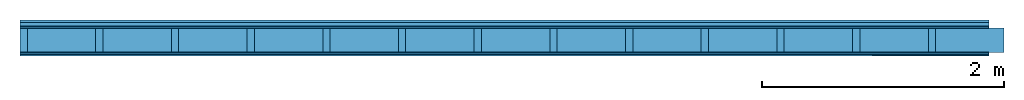
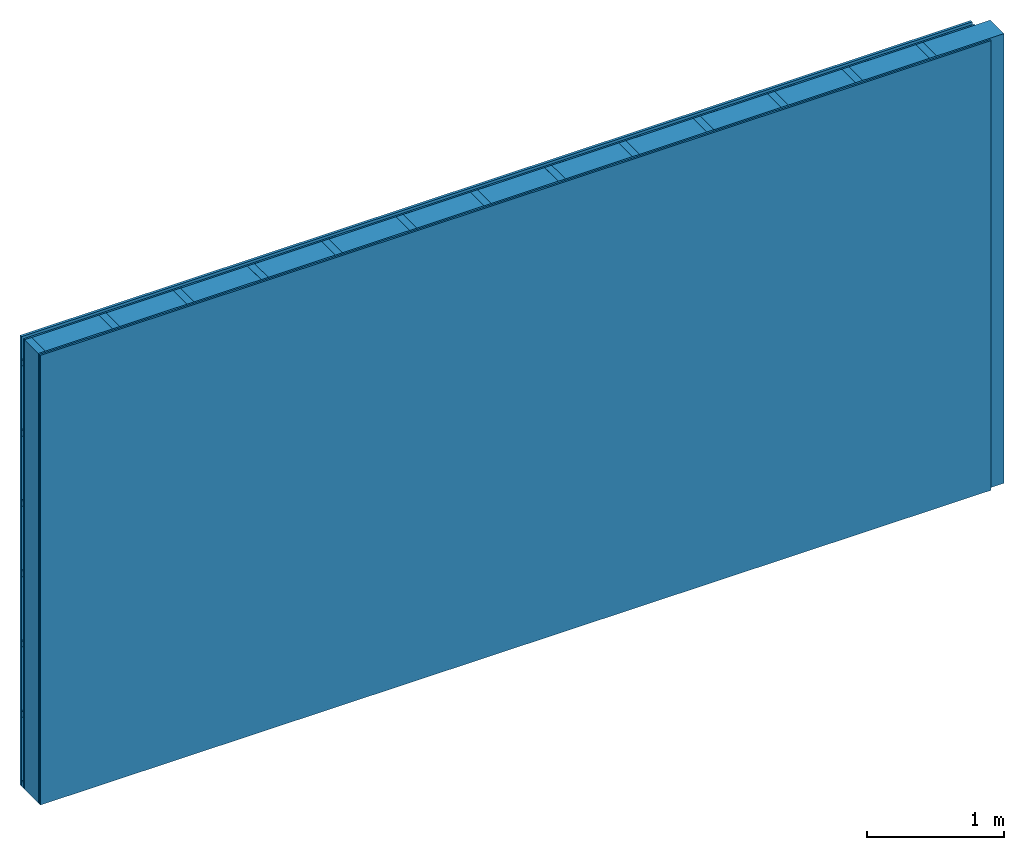
# One storey: 4 plates, 3 members, 1 element without a shape of its own.
"""IFC4 building model written with IfcOpenShell, lengths in metres."""

from ifc_helpers import new_model, si_unit, derived_unit, direction, frame, frame_2d, origin, origin_with_axes, place, context, project, spatial, rectangle, extrude, material, layer, layer_set, type_object, element, aggregate, save


model = new_model("IFC4")

# Units and contexts
plan_context = context("Plan", 3, precision=1e-05, world=origin(), true_north=direction((0.0, 1.0)))
model_context = context("Model", 3, precision=1e-05, world=origin(), true_north=direction((0.0, 1.0)))
ifc_project = project(units=[si_unit("LENGTHUNIT", "METRE"), derived_unit("SOUNDPRESSUREUNIT", [(si_unit("PRESSUREUNIT", "PASCAL", prefix="MICRO"), 0)]), si_unit("ENERGYUNIT", "JOULE", prefix="MEGA"), si_unit("MASSUNIT", "GRAM", prefix="KILO"), derived_unit("THERMALTRANSMITTANCEUNIT", [(si_unit("POWERUNIT", "WATT"), 1), (si_unit("AREAUNIT", "SQUARE_METRE"), -1), (si_unit("THERMODYNAMICTEMPERATUREUNIT", "KELVIN"), -1)]), derived_unit("AREADENSITYUNIT", [(si_unit("MASSUNIT", "GRAM", prefix="KILO"), 1), (si_unit("AREAUNIT", "SQUARE_METRE"), -1)]), derived_unit("USERDEFINED", [(si_unit("ENERGYUNIT", "JOULE", prefix="MEGA"), 1), (si_unit("AREAUNIT", "SQUARE_METRE"), -1)])], contexts=[plan_context, model_context])

# Site, building, storey
site = spatial("IfcSite", under=ifc_project)
building_placement = place(None, origin())
building = spatial("IfcBuilding", under=site, at=building_placement)
storey_placement = place(building_placement, origin())
storey = spatial("IfcBuildingStorey", under=building, at=storey_placement)

# Wall, members, plates
ifc_material_1 = material(Name="Wood cladding horizontal, closed")
ifc_layer_1 = layer(ifc_material_1, 0.022, Name="Cover 1st layer")
ifc_layer_2 = layer(None, 0.03, Name="Battens / profiles (ventilation)")
ifc_material_2 = material(Category="03.007")
ifc_layer_3 = layer(ifc_material_2, 0.015, Name="outside 1st layer")
ifc_material_3 = material(Name="of the art")
ifc_layer_4 = layer(ifc_material_3, 0.0, Name="Bond")
ifc_layer_5 = layer(None, 0.2, Name="Support")
ifc_layer_6 = layer(ifc_material_3, 0.0, Name="Bond")
ifc_material_4 = material(Category="07.013")
ifc_layer_7 = layer(ifc_material_4, 0.015, Name="1st layer")
ifc_material_5 = material(Name="Plasterboard type A", Category="03.008")
ifc_layer_8 = layer(ifc_material_5, 0.015, Name="2nd layer")
ifc_material_6 = material(Name="joints", Category="04.017")
ifc_layer_9 = layer(ifc_material_6, 0.0, Name="Surface")
ifc_layer_set = layer_set([ifc_layer_1, ifc_layer_2, ifc_layer_3, ifc_layer_4, ifc_layer_5, ifc_layer_6, ifc_layer_7, ifc_layer_8, ifc_layer_9])
wall_type = type_object("IfcWallType", Name="D0128", PredefinedType="NOTDEFINED", material=ifc_layer_set)
wall_placement = place(None, frame((0.0, 0.0, 0.0), z_axis=(0.0, -1.0, 0.0), x_axis=(1.0, 0.0, 0.0)))
wall = element("IfcWall", 1, at=wall_placement, inside=storey, type_object=wall_type, material=ifc_layer_set, Name="Wall #1")
ifc_material_7 = material()
member_1_placement = place(wall_placement, origin())
member_1 = element("IfcMember", 2, at=member_1_placement, material=ifc_material_7, Name="Battens / profiles (ventilation)", context=plan_context, shape_type="SweptSolid", body=[
    extrude(rectangle(XDim=0.05, YDim=0.03, at=frame_2d((0.025, 0.015), x_axis=(1.0, 0.0))), frame((0.0, 0.0, 0.022), z_axis=(1.0, 0.0, 0.0), x_axis=(0.0, 1.0, 0.0)), (0.0, 0.0, 1.0), 8.0),
    extrude(rectangle(XDim=0.05, YDim=0.03, at=frame_2d((0.025, 0.015), x_axis=(1.0, 0.0))), frame((0.0, 0.625, 0.022), z_axis=(1.0, 0.0, 0.0), x_axis=(0.0, 1.0, 0.0)), (0.0, 0.0, 1.0), 8.0),
    extrude(rectangle(XDim=0.05, YDim=0.03, at=frame_2d((0.025, 0.015), x_axis=(1.0, 0.0))), frame((0.0, 1.25, 0.022), z_axis=(1.0, 0.0, 0.0), x_axis=(0.0, 1.0, 0.0)), (0.0, 0.0, 1.0), 8.0),
    extrude(rectangle(XDim=0.05, YDim=0.03, at=frame_2d((0.025, 0.015), x_axis=(1.0, 0.0))), frame((0.0, 1.875, 0.022), z_axis=(1.0, 0.0, 0.0), x_axis=(0.0, 1.0, 0.0)), (0.0, 0.0, 1.0), 8.0),
    extrude(rectangle(XDim=0.05, YDim=0.03, at=frame_2d((0.025, 0.015), x_axis=(1.0, 0.0))), frame((0.0, 2.5, 0.022), z_axis=(1.0, 0.0, 0.0), x_axis=(0.0, 1.0, 0.0)), (0.0, 0.0, 1.0), 8.0),
    extrude(rectangle(XDim=0.05, YDim=0.03, at=frame_2d((0.025, 0.015), x_axis=(1.0, 0.0))), frame((0.0, 3.125, 0.022), z_axis=(1.0, 0.0, 0.0), x_axis=(0.0, 1.0, 0.0)), (0.0, 0.0, 1.0), 8.0),
    extrude(rectangle(XDim=0.05, YDim=0.03, at=frame_2d((0.025, 0.015), x_axis=(1.0, 0.0))), frame((0.0, 3.75, 0.022), z_axis=(1.0, 0.0, 0.0), x_axis=(0.0, 1.0, 0.0)), (0.0, 0.0, 1.0), 8.0),
])
ifc_material_8 = material()
member_2_placement = place(wall_placement, origin())
member_2 = element("IfcMember", 3, at=member_2_placement, material=ifc_material_8, Name="Support", context=plan_context, shape_type="SweptSolid", body=[
    extrude(rectangle(XDim=0.06, YDim=0.2, at=frame_2d((0.03, 0.1), x_axis=(1.0, 0.0))), frame((0.0, 4.0, 0.067), z_axis=(0.0, -1.0, 0.0), x_axis=(1.0, 0.0, 0.0)), (0.0, 0.0, 1.0), 4.0),
    extrude(rectangle(XDim=0.06, YDim=0.2, at=frame_2d((0.03, 0.1), x_axis=(1.0, 0.0))), frame((0.625, 4.0, 0.067), z_axis=(0.0, -1.0, 0.0), x_axis=(1.0, 0.0, 0.0)), (0.0, 0.0, 1.0), 4.0),
    extrude(rectangle(XDim=0.06, YDim=0.2, at=frame_2d((0.03, 0.1), x_axis=(1.0, 0.0))), frame((1.25, 4.0, 0.067), z_axis=(0.0, -1.0, 0.0), x_axis=(1.0, 0.0, 0.0)), (0.0, 0.0, 1.0), 4.0),
    extrude(rectangle(XDim=0.06, YDim=0.2, at=frame_2d((0.03, 0.1), x_axis=(1.0, 0.0))), frame((1.875, 4.0, 0.067), z_axis=(0.0, -1.0, 0.0), x_axis=(1.0, 0.0, 0.0)), (0.0, 0.0, 1.0), 4.0),
    extrude(rectangle(XDim=0.06, YDim=0.2, at=frame_2d((0.03, 0.1), x_axis=(1.0, 0.0))), frame((2.5, 4.0, 0.067), z_axis=(0.0, -1.0, 0.0), x_axis=(1.0, 0.0, 0.0)), (0.0, 0.0, 1.0), 4.0),
    extrude(rectangle(XDim=0.06, YDim=0.2, at=frame_2d((0.03, 0.1), x_axis=(1.0, 0.0))), frame((3.125, 4.0, 0.067), z_axis=(0.0, -1.0, 0.0), x_axis=(1.0, 0.0, 0.0)), (0.0, 0.0, 1.0), 4.0),
    extrude(rectangle(XDim=0.06, YDim=0.2, at=frame_2d((0.03, 0.1), x_axis=(1.0, 0.0))), frame((3.75, 4.0, 0.067), z_axis=(0.0, -1.0, 0.0), x_axis=(1.0, 0.0, 0.0)), (0.0, 0.0, 1.0), 4.0),
    extrude(rectangle(XDim=0.06, YDim=0.2, at=frame_2d((0.03, 0.1), x_axis=(1.0, 0.0))), frame((4.375, 4.0, 0.067), z_axis=(0.0, -1.0, 0.0), x_axis=(1.0, 0.0, 0.0)), (0.0, 0.0, 1.0), 4.0),
    extrude(rectangle(XDim=0.06, YDim=0.2, at=frame_2d((0.03, 0.1), x_axis=(1.0, 0.0))), frame((5.0, 4.0, 0.067), z_axis=(0.0, -1.0, 0.0), x_axis=(1.0, 0.0, 0.0)), (0.0, 0.0, 1.0), 4.0),
    extrude(rectangle(XDim=0.06, YDim=0.2, at=frame_2d((0.03, 0.1), x_axis=(1.0, 0.0))), frame((5.625, 4.0, 0.067), z_axis=(0.0, -1.0, 0.0), x_axis=(1.0, 0.0, 0.0)), (0.0, 0.0, 1.0), 4.0),
    extrude(rectangle(XDim=0.06, YDim=0.2, at=frame_2d((0.03, 0.1), x_axis=(1.0, 0.0))), frame((6.25, 4.0, 0.067), z_axis=(0.0, -1.0, 0.0), x_axis=(1.0, 0.0, 0.0)), (0.0, 0.0, 1.0), 4.0),
    extrude(rectangle(XDim=0.06, YDim=0.2, at=frame_2d((0.03, 0.1), x_axis=(1.0, 0.0))), frame((6.875, 4.0, 0.067), z_axis=(0.0, -1.0, 0.0), x_axis=(1.0, 0.0, 0.0)), (0.0, 0.0, 1.0), 4.0),
    extrude(rectangle(XDim=0.06, YDim=0.2, at=frame_2d((0.03, 0.1), x_axis=(1.0, 0.0))), frame((7.5, 4.0, 0.067), z_axis=(0.0, -1.0, 0.0), x_axis=(1.0, 0.0, 0.0)), (0.0, 0.0, 1.0), 4.0),
])
ifc_material_9 = material()
member_3_placement = place(wall_placement, origin())
member_3 = element("IfcMember", 4, at=member_3_placement, material=ifc_material_9, Name="Cavity", context=plan_context, shape_type="SweptSolid", body=[
    extrude(rectangle(XDim=0.565, YDim=0.2, at=frame_2d((0.2825, 0.1), x_axis=(1.0, 0.0))), frame((0.06, 4.0, 0.067), z_axis=(0.0, -1.0, 0.0), x_axis=(1.0, 0.0, 0.0)), (0.0, 0.0, 1.0), 4.0),
    extrude(rectangle(XDim=0.565, YDim=0.2, at=frame_2d((0.2825, 0.1), x_axis=(1.0, 0.0))), frame((0.685, 4.0, 0.067), z_axis=(0.0, -1.0, 0.0), x_axis=(1.0, 0.0, 0.0)), (0.0, 0.0, 1.0), 4.0),
    extrude(rectangle(XDim=0.565, YDim=0.2, at=frame_2d((0.2825, 0.1), x_axis=(1.0, 0.0))), frame((1.31, 4.0, 0.067), z_axis=(0.0, -1.0, 0.0), x_axis=(1.0, 0.0, 0.0)), (0.0, 0.0, 1.0), 4.0),
    extrude(rectangle(XDim=0.565, YDim=0.2, at=frame_2d((0.2825, 0.1), x_axis=(1.0, 0.0))), frame((1.935, 4.0, 0.067), z_axis=(0.0, -1.0, 0.0), x_axis=(1.0, 0.0, 0.0)), (0.0, 0.0, 1.0), 4.0),
    extrude(rectangle(XDim=0.565, YDim=0.2, at=frame_2d((0.2825, 0.1), x_axis=(1.0, 0.0))), frame((2.56, 4.0, 0.067), z_axis=(0.0, -1.0, 0.0), x_axis=(1.0, 0.0, 0.0)), (0.0, 0.0, 1.0), 4.0),
    extrude(rectangle(XDim=0.565, YDim=0.2, at=frame_2d((0.2825, 0.1), x_axis=(1.0, 0.0))), frame((3.185, 4.0, 0.067), z_axis=(0.0, -1.0, 0.0), x_axis=(1.0, 0.0, 0.0)), (0.0, 0.0, 1.0), 4.0),
    extrude(rectangle(XDim=0.565, YDim=0.2, at=frame_2d((0.2825, 0.1), x_axis=(1.0, 0.0))), frame((3.81, 4.0, 0.067), z_axis=(0.0, -1.0, 0.0), x_axis=(1.0, 0.0, 0.0)), (0.0, 0.0, 1.0), 4.0),
    extrude(rectangle(XDim=0.565, YDim=0.2, at=frame_2d((0.2825, 0.1), x_axis=(1.0, 0.0))), frame((4.435, 4.0, 0.067), z_axis=(0.0, -1.0, 0.0), x_axis=(1.0, 0.0, 0.0)), (0.0, 0.0, 1.0), 4.0),
    extrude(rectangle(XDim=0.565, YDim=0.2, at=frame_2d((0.2825, 0.1), x_axis=(1.0, 0.0))), frame((5.06, 4.0, 0.067), z_axis=(0.0, -1.0, 0.0), x_axis=(1.0, 0.0, 0.0)), (0.0, 0.0, 1.0), 4.0),
    extrude(rectangle(XDim=0.565, YDim=0.2, at=frame_2d((0.2825, 0.1), x_axis=(1.0, 0.0))), frame((5.685, 4.0, 0.067), z_axis=(0.0, -1.0, 0.0), x_axis=(1.0, 0.0, 0.0)), (0.0, 0.0, 1.0), 4.0),
    extrude(rectangle(XDim=0.565, YDim=0.2, at=frame_2d((0.2825, 0.1), x_axis=(1.0, 0.0))), frame((6.31, 4.0, 0.067), z_axis=(0.0, -1.0, 0.0), x_axis=(1.0, 0.0, 0.0)), (0.0, 0.0, 1.0), 4.0),
    extrude(rectangle(XDim=0.565, YDim=0.2, at=frame_2d((0.2825, 0.1), x_axis=(1.0, 0.0))), frame((6.935, 4.0, 0.067), z_axis=(0.0, -1.0, 0.0), x_axis=(1.0, 0.0, 0.0)), (0.0, 0.0, 1.0), 4.0),
    extrude(rectangle(XDim=0.565, YDim=0.2, at=frame_2d((0.2825, 0.1), x_axis=(1.0, 0.0))), frame((7.56, 4.0, 0.067), z_axis=(0.0, -1.0, 0.0), x_axis=(1.0, 0.0, 0.0)), (0.0, 0.0, 1.0), 4.0),
])
plate_1_placement = place(wall_placement, origin())
plate_1 = element("IfcPlate", 5, at=plate_1_placement, material=ifc_material_1, Name="Cover 1st layer", context=plan_context, shape_type="SweptSolid", body=[
    extrude(rectangle(XDim=8.0, YDim=4.0, at=frame_2d((4.0, 2.0), x_axis=(1.0, 0.0))), origin_with_axes(), (0.0, 0.0, 1.0), 0.022),
])
plate_2_placement = place(wall_placement, origin())
plate_2 = element("IfcPlate", 6, at=plate_2_placement, material=ifc_material_2, Name="outside 1st layer", context=plan_context, shape_type="SweptSolid", body=[
    extrude(rectangle(XDim=8.0, YDim=4.0, at=frame_2d((4.0, 2.0), x_axis=(1.0, 0.0))), frame((0.0, 0.0, 0.052), z_axis=(0.0, 0.0, 1.0), x_axis=(1.0, 0.0, 0.0)), (0.0, 0.0, 1.0), 0.015),
])
plate_3_placement = place(wall_placement, origin())
plate_3 = element("IfcPlate", 7, at=plate_3_placement, material=ifc_material_4, Name="1st layer", context=plan_context, shape_type="SweptSolid", body=[
    extrude(rectangle(XDim=8.0, YDim=4.0, at=frame_2d((4.0, 2.0), x_axis=(1.0, 0.0))), frame((0.0, 0.0, 0.267), z_axis=(0.0, 0.0, 1.0), x_axis=(1.0, 0.0, 0.0)), (0.0, 0.0, 1.0), 0.015),
])
plate_4_placement = place(wall_placement, origin())
plate_4 = element("IfcPlate", 8, at=plate_4_placement, material=ifc_material_5, Name="2nd layer", context=plan_context, shape_type="SweptSolid", body=[
    extrude(rectangle(XDim=8.0, YDim=4.0, at=frame_2d((4.0, 2.0), x_axis=(1.0, 0.0))), frame((0.0, 0.0, 0.282), z_axis=(0.0, 0.0, 1.0), x_axis=(1.0, 0.0, 0.0)), (0.0, 0.0, 1.0), 0.015),
])
aggregate(wall, [plate_1, member_1, plate_2, member_2, member_3, plate_3, plate_4])

save(model, "model.ifc")
